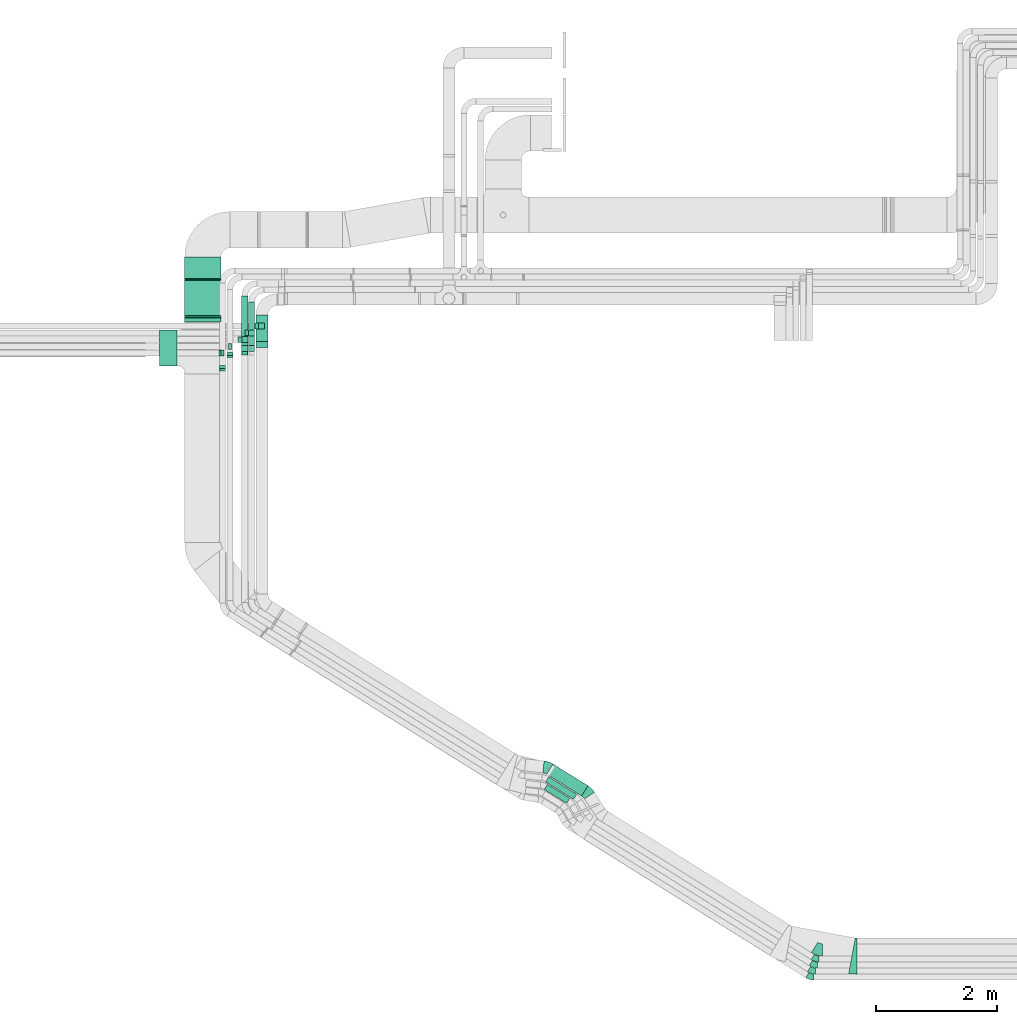
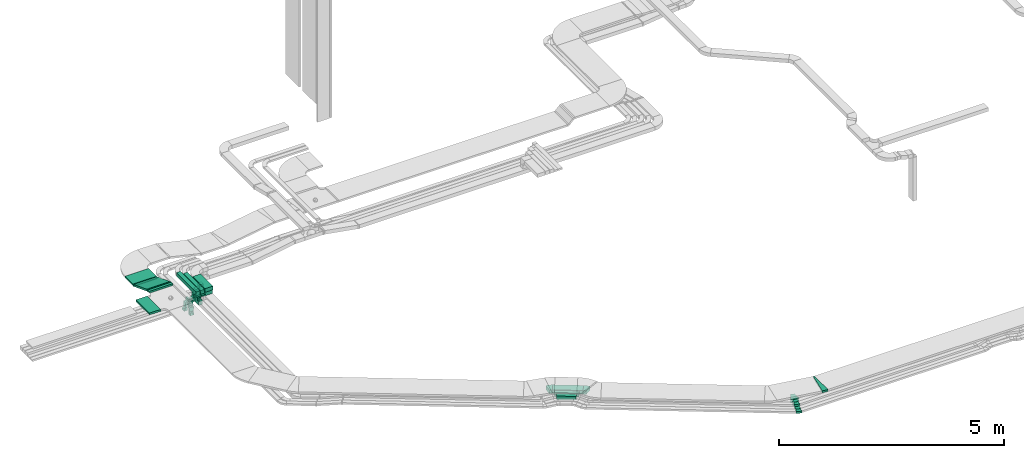
# One storey, part 7 of 28: 20 flow segments, 17 flow fittings.
"""IFC2X3 building model written with IfcOpenShell, lengths in millimetres."""

from ifc_helpers import new_model, entity, si_unit, converted_unit, derived_unit, direction, frame, frame_2d, origin, origin_2d_with_axis, place, context, subcontext, project, spatial, polyline, circle_curve, parameter, trimmed, segment, composite_curve, rectangle, outline, extrude, faceted_brep, source, transform, mapped, material, type_object, type_shapes, element, save


model = new_model("IFC2X3")

# Units and contexts
model_context = context("Model", 3, precision=0.01, world=origin(), true_north=direction((6.12303176911189e-17, 1.0)))
body_context = subcontext(model_context, "Body", "Model", "MODEL_VIEW")
ifc_project = project(units=[si_unit("LENGTHUNIT", "METRE", prefix="MILLI"), si_unit("AREAUNIT", "SQUARE_METRE"), si_unit("VOLUMEUNIT", "CUBIC_METRE"), converted_unit("PLANEANGLEUNIT", "DEGREE", entity("IfcRatioMeasure", 0.0174532925199433), si_unit("PLANEANGLEUNIT", "RADIAN"), dimensions=[0, 0, 0, 0, 0, 0, 0]), si_unit("MASSUNIT", "GRAM", prefix="KILO"), derived_unit("MASSDENSITYUNIT", [(si_unit("MASSUNIT", "GRAM", prefix="KILO"), 1), (si_unit("LENGTHUNIT", "METRE"), -3)]), derived_unit("MOMENTOFINERTIAUNIT", [(si_unit("LENGTHUNIT", "METRE"), 4)]), si_unit("TIMEUNIT", "SECOND"), si_unit("FREQUENCYUNIT", "HERTZ"), si_unit("THERMODYNAMICTEMPERATUREUNIT", "DEGREE_CELSIUS"), derived_unit("THERMALTRANSMITTANCEUNIT", [(si_unit("MASSUNIT", "GRAM", prefix="KILO"), 1), (si_unit("THERMODYNAMICTEMPERATUREUNIT", "KELVIN"), -1), (si_unit("TIMEUNIT", "SECOND"), -3)]), derived_unit("VOLUMETRICFLOWRATEUNIT", [(si_unit("LENGTHUNIT", "METRE"), 3), (si_unit("TIMEUNIT", "SECOND"), -1)]), derived_unit("MASSFLOWRATEUNIT", [(si_unit("MASSUNIT", "GRAM", prefix="KILO"), 1), (si_unit("TIMEUNIT", "SECOND"), -1)]), derived_unit("ROTATIONALFREQUENCYUNIT", [(si_unit("TIMEUNIT", "SECOND"), -1)]), si_unit("ELECTRICCURRENTUNIT", "AMPERE"), si_unit("ELECTRICVOLTAGEUNIT", "VOLT"), si_unit("POWERUNIT", "WATT"), si_unit("FORCEUNIT", "NEWTON", prefix="KILO"), si_unit("ILLUMINANCEUNIT", "LUX"), si_unit("LUMINOUSFLUXUNIT", "LUMEN"), si_unit("LUMINOUSINTENSITYUNIT", "CANDELA"), derived_unit("USERDEFINED", [(si_unit("MASSUNIT", "GRAM", prefix="KILO"), -1), (si_unit("LENGTHUNIT", "METRE"), -2), (si_unit("TIMEUNIT", "SECOND"), 3), (si_unit("LUMINOUSFLUXUNIT", "LUMEN"), 1)]), derived_unit("LINEARVELOCITYUNIT", [(si_unit("LENGTHUNIT", "METRE"), 1), (si_unit("TIMEUNIT", "SECOND"), -1)]), si_unit("PRESSUREUNIT", "PASCAL"), derived_unit("USERDEFINED", [(si_unit("LENGTHUNIT", "METRE"), -2), (si_unit("MASSUNIT", "GRAM", prefix="KILO"), 1), (si_unit("TIMEUNIT", "SECOND"), -2)]), derived_unit("LINEARFORCEUNIT", [(si_unit("MASSUNIT", "GRAM", prefix="KILO"), 1), (si_unit("LENGTHUNIT", "METRE"), 1), (si_unit("TIMEUNIT", "SECOND"), -2), (si_unit("LENGTHUNIT", "METRE"), -1)]), derived_unit("PLANARFORCEUNIT", [(si_unit("MASSUNIT", "GRAM", prefix="KILO"), 1), (si_unit("LENGTHUNIT", "METRE"), 1), (si_unit("TIMEUNIT", "SECOND"), -2), (si_unit("LENGTHUNIT", "METRE"), -2)])], contexts=[model_context])

# Site, building, storey
site_placement = place(None, origin())
site = spatial("IfcSite", under=ifc_project, at=site_placement, CompositionType="ELEMENT")
building_placement = place(site_placement, origin())
building = spatial("IfcBuilding", under=site, at=building_placement, CompositionType="ELEMENT")
storey_placement = place(building_placement, frame((0.0, 0.0, 4200.0)))
storey = spatial("IfcBuildingStorey", under=building, at=storey_placement, CompositionType="ELEMENT", Elevation=4200.0)

# Flow segments
cable_carrier_segment_type = type_object("IfcCableCarrierSegmentType", PredefinedType="CABLETRAYSEGMENT")
flow_segment_1_placement = place(storey_placement, frame((16162.99, 3174.28, 2836.0)))
element("IfcFlowSegment", 1, at=flow_segment_1_placement, inside=storey, type_object=cable_carrier_segment_type, context=body_context, shape_type="SweptSolid", body=[
    extrude(rectangle(XDim=440.17831343898, YDim=100.000000000001, at=origin_2d_with_axis()), frame((213.14, 159.03, 0.0), z_axis=(0.0, 0.0, 1.0), x_axis=(0.848048096156428, -0.529919264233201, 0.0)), (0.0, 0.0, 1.0), 99.9999999999989),
])
flow_segment_2_placement = place(storey_placement, frame((16188.32, 3242.66, 2836.0)))
element("IfcFlowSegment", 2, at=flow_segment_2_placement, inside=storey, type_object=cable_carrier_segment_type, context=body_context, shape_type="SweptSolid", body=[
    extrude(rectangle(XDim=544.386639758855, YDim=100.000000000001, at=origin_2d_with_axis()), frame((257.33, 186.64, 0.0), z_axis=(0.0, 0.0, 1.0), x_axis=(0.848048096156427, -0.529919264233204, 0.0)), (0.0, 0.0, 1.0), 99.9999999999989),
])
flow_segment_3_placement = place(storey_placement, frame((16206.86, 3298.15, 2836.0)))
element("IfcFlowSegment", 3, at=flow_segment_3_placement, inside=storey, type_object=cable_carrier_segment_type, context=body_context, shape_type="SweptSolid", body=[
    extrude(rectangle(XDim=680.786011222214, YDim=200.000000000001, at=origin_2d_with_axis()), frame((341.66, 265.19, 0.0), z_axis=(0.0, 0.0, 1.0), x_axis=(0.848048096156428, -0.529919264233203, 0.0)), (0.0, 0.0, 1.0), 99.9999999999989),
])
flow_segment_4_placement = place(storey_placement, frame((11383.59, 10733.65, 2975.0)))
element("IfcFlowSegment", 4, at=flow_segment_4_placement, inside=storey, type_object=cable_carrier_segment_type, context=body_context, shape_type="SweptSolid", body=[
    extrude(rectangle(XDim=544.131004135629, YDim=200.000000000002, at=origin_2d_with_axis()), frame((100.0, 272.07, 0.0), z_axis=(0.0, 0.0, 1.0), x_axis=(0.0, -1.0, 0.0)), (0.0, 0.0, 1.0), 100.0),
])
flow_segment_5_placement = place(storey_placement, frame((9785.26, 10426.35, 3110.0)))
element("IfcFlowSegment", 5, at=flow_segment_5_placement, inside=storey, type_object=cable_carrier_segment_type, context=body_context, shape_type="SweptSolid", body=[
    extrude(rectangle(XDim=288.329147634272, YDim=600.000000000002, at=origin_2d_with_axis()), frame((144.16, 300.0, 0.0), z_axis=(0.0, 0.0, 1.0), x_axis=(-1.0, 0.0, 0.0)), (0.0, 0.0, 1.0), 49.9999999999995),
])
flow_segment_6_placement = place(storey_placement, frame((10203.59, 11156.35, 3108.85)))
element("IfcFlowSegment", 6, at=flow_segment_6_placement, inside=storey, type_object=cable_carrier_segment_type, context=body_context, shape_type="SweptSolid", body=[
    extrude(rectangle(XDim=67.4394769447223, YDim=600.000000000002, at=origin_2d_with_axis()), frame((300.0, 33.72, 0.0), z_axis=(0.0, 0.0, 1.0), x_axis=(0.0, 1.0, 0.0)), (0.0, 0.0, 1.0), 49.9999999999995),
])
flow_segment_7_placement = place(storey_placement, frame((10203.59, 11244.21, 2875.16)))
element("IfcFlowSegment", 7, at=flow_segment_7_placement, inside=storey, type_object=cable_carrier_segment_type, context=body_context, shape_type="SweptSolid", body=[
    extrude(rectangle(XDim=49.9999999999996, YDim=641.534146168954, at=frame_2d((0.0, 0.0), x_axis=(0.0, 1.0))), frame((0.0, 308.42, 138.29), z_axis=(1.0, 0.0, 0.0), x_axis=(0.0, 0.933580426497194, -0.35836794954532)), (0.0, 0.0, 1.0), 600.000000000002),
])
flow_segment_8_placement = place(storey_placement, frame((10203.59, 11881.47, 2868.06)))
element("IfcFlowSegment", 8, at=flow_segment_8_placement, inside=storey, type_object=cable_carrier_segment_type, context=body_context, shape_type="SweptSolid", body=[
    extrude(rectangle(XDim=354.579149652475, YDim=600.000000000002, at=origin_2d_with_axis()), frame((300.0, 177.29, 0.0), z_axis=(0.0, 0.0, 1.0), x_axis=(0.0, -1.0, 0.0)), (0.0, 0.0, 1.0), 49.9999999999995),
])
flow_segment_9_placement = place(storey_placement, frame((11427.64, 11042.31, 2920.0)))
element("IfcFlowSegment", 9, at=flow_segment_9_placement, inside=storey, type_object=cable_carrier_segment_type, context=body_context, shape_type="SweptSolid", body=[
    extrude(rectangle(XDim=99.9999999999989, YDim=99.9999999999989, at=origin_2d_with_axis()), frame((50.0, 50.0, 0.0)), (0.0, 0.0, 1.0), 54.999999999903),
])
flow_segment_10_placement = place(storey_placement, frame((11383.59, 10735.23, 2880.0)))
element("IfcFlowSegment", 10, at=flow_segment_10_placement, inside=storey, type_object=cable_carrier_segment_type, context=body_context, shape_type="SweptSolid", body=[
    extrude(rectangle(XDim=200.000000000002, YDim=99.9999999999989, at=origin_2d_with_axis()), frame((100.0, 50.0, 0.0)), (0.0, 0.0, 1.0), 94.9999999996622),
])
flow_segment_11_placement = place(storey_placement, frame((11263.59, 10716.85, 2975.0)))
element("IfcFlowSegment", 11, at=flow_segment_11_placement, inside=storey, type_object=cable_carrier_segment_type, context=body_context, shape_type="SweptSolid", body=[
    extrude(rectangle(XDim=769.000000000009, YDim=99.9999999999989, at=origin_2d_with_axis()), frame((50.0, 384.5, 0.0), z_axis=(0.0, 0.0, 1.0), x_axis=(0.0, -1.0, 0.0)), (0.0, 0.0, 1.0), 100.000000000001),
])
flow_segment_12_placement = place(storey_placement, frame((11263.59, 10928.65, 2920.0)))
element("IfcFlowSegment", 12, at=flow_segment_12_placement, inside=storey, type_object=cable_carrier_segment_type, context=body_context, shape_type="SweptSolid", body=[
    extrude(rectangle(XDim=99.9999999999989, YDim=99.9999999999989, at=origin_2d_with_axis()), frame((50.0, 50.0, 0.0), z_axis=(0.0, 0.0, 1.0), x_axis=(0.0, -1.0, 0.0)), (0.0, 0.0, 1.0), 54.9999999997298),
])
flow_segment_13_placement = place(storey_placement, frame((11148.59, 10716.85, 2975.0)))
element("IfcFlowSegment", 13, at=flow_segment_13_placement, inside=storey, type_object=cable_carrier_segment_type, context=body_context, shape_type="SweptSolid", body=[
    extrude(rectangle(XDim=876.10399562814, YDim=99.9999999999989, at=origin_2d_with_axis()), frame((50.0, 438.05, 0.0), z_axis=(0.0, 0.0, 1.0), x_axis=(0.0, -1.0, 0.0)), (0.0, 0.0, 1.0), 99.9999999999978),
])
flow_segment_14_placement = place(storey_placement, frame((11148.59, 10667.04, 2940.0)))
element("IfcFlowSegment", 14, at=flow_segment_14_placement, inside=storey, type_object=cable_carrier_segment_type, context=body_context, shape_type="SweptSolid", body=[
    extrude(rectangle(XDim=99.9999999999989, YDim=99.9999999999989, at=origin_2d_with_axis()), frame((50.0, 50.0, 0.0), z_axis=(0.0, 0.0, 1.0), x_axis=(-1.0, 0.0, 0.0)), (0.0, 0.0, 1.0), 34.9999999999931),
])
flow_segment_15_placement = place(storey_placement, frame((11263.59, 10667.04, 2939.59)))
element("IfcFlowSegment", 15, at=flow_segment_15_placement, inside=storey, type_object=cable_carrier_segment_type, context=body_context, shape_type="SweptSolid", body=[
    extrude(rectangle(XDim=99.9999999999989, YDim=99.9999999999989, at=origin_2d_with_axis()), frame((50.0, 50.0, 0.0), z_axis=(0.0, 0.0, 1.0), x_axis=(-1.0, 0.0, 0.0)), (0.0, 0.0, 1.0), 35.408361324178),
])
flow_segment_16_placement = place(storey_placement, frame((10903.59, 10601.71, 2865.0)))
element("IfcFlowSegment", 16, at=flow_segment_16_placement, inside=storey, type_object=cable_carrier_segment_type, context=body_context, shape_type="SweptSolid", body=[
    extrude(rectangle(XDim=50.0000000000016, YDim=99.9999999999989, at=origin_2d_with_axis()), frame((50.0, 25.0, 0.0), z_axis=(0.0, 0.0, 1.0), x_axis=(0.0, -1.0, 0.0)), (0.0, 0.0, 1.0), 110.000000000012),
])
flow_segment_17_placement = place(storey_placement, frame((11150.72, 10815.79, 2920.0)))
element("IfcFlowSegment", 17, at=flow_segment_17_placement, inside=storey, type_object=cable_carrier_segment_type, context=body_context, shape_type="SweptSolid", body=[
    extrude(rectangle(XDim=99.9999999999989, YDim=99.9999999999989, at=origin_2d_with_axis()), frame((50.0, 50.0, 0.0), z_axis=(0.0, 0.0, 1.0), x_axis=(0.0, 1.0, 0.0)), (0.0, 0.0, 1.0), 54.9999999999951),
])
flow_segment_18_placement = place(storey_placement, frame((10928.59, 10700.79, 2810.0)))
element("IfcFlowSegment", 18, at=flow_segment_18_placement, inside=storey, type_object=cable_carrier_segment_type, context=body_context, shape_type="SweptSolid", body=[
    extrude(rectangle(XDim=99.9999999999989, YDim=50.0000000000016, at=origin_2d_with_axis()), frame((25.0, 50.0, 0.0), z_axis=(0.0, 0.0, 1.0), x_axis=(0.0, -1.0, 0.0)), (0.0, 0.0, 1.0), 165.000000000001),
])
flow_segment_19_placement = place(storey_placement, frame((10783.59, 10384.17, 2865.0)))
element("IfcFlowSegment", 19, at=flow_segment_19_placement, inside=storey, type_object=cable_carrier_segment_type, context=body_context, shape_type="SweptSolid", body=[
    extrude(rectangle(XDim=99.9999999999989, YDim=50.0000000000016, at=origin_2d_with_axis()), frame((50.0, 25.0, 0.0), z_axis=(0.0, 0.0, 1.0), x_axis=(-1.0, 0.0, 0.0)), (0.0, 0.0, 1.0), 110.000000000005),
])
flow_segment_20_placement = place(storey_placement, frame((10808.59, 10590.79, 2845.0)))
element("IfcFlowSegment", 20, at=flow_segment_20_placement, inside=storey, type_object=cable_carrier_segment_type, context=body_context, shape_type="SweptSolid", body=[
    extrude(rectangle(XDim=99.9999999999989, YDim=50.0000000000016, at=origin_2d_with_axis()), frame((25.0, 50.0, 0.0), z_axis=(0.0, 0.0, 1.0), x_axis=(0.0, 1.0, 0.0)), (0.0, 0.0, 1.0), 130.000000000003),
])

# Flow fittings
ifc_material = material()
cable_carrier_fitting_type_1 = type_object("IfcCableCarrierFittingType", PredefinedType="NOTDEFINED", material=ifc_material)
shared_shape_1 = source(origin(), body_context, "Body", "Brep", [
    faceted_brep([(-15.19, -25.0, 300.0), (-15.19, 25.0, 300.0), (-15.19, 25.0, 297.46), (-15.19, -22.46, 297.46), (-15.19, -22.46, -297.46), (-15.19, 25.0, -297.46), (-15.19, 25.0, -300.0), (-15.19, -25.0, -300.0), (23.14, -17.89, 300.0), (23.14, -17.89, -300.0), (5.23, 28.78, -300.0), (5.23, 28.78, -297.46), (22.23, -15.52, -297.46), (22.23, -15.52, 297.46), (5.23, 28.78, 297.46), (5.23, 28.78, 300.0), (4.63, -25.0, 300.0), (-4.63, 25.0, 300.0), (-4.63, 25.0, 297.46), (4.16, -22.46, 297.46), (4.16, -22.46, -297.46), (-4.63, 25.0, -297.46), (-4.63, 25.0, -300.0), (4.63, -25.0, -300.0)], [[[0, 1, 2, 3, 4, 5, 6, 7]], [[8, 9, 10, 11, 12, 13, 14, 15]], [[1, 0, 16, 8, 15, 17]], [[2, 1, 17, 18]], [[3, 2, 18, 14, 13, 19]], [[4, 3, 19, 20]], [[5, 4, 20, 12, 11, 21]], [[6, 5, 21, 22]], [[7, 6, 22, 10, 9, 23]], [[0, 7, 23, 16]], [[18, 17, 15, 14]], [[20, 19, 13, 12]], [[22, 21, 11, 10]], [[16, 23, 9, 8]]]),
])
type_shapes(cable_carrier_fitting_type_1, [shared_shape_1])
for number, where, z_axis, x_axis in (
    (21, (10503.59, 11238.98, 3133.85), (-1.0, 0.0, 0.0), (0.0, 1.0, 0.0)),
    (22, (10503.59, 11866.28, 2893.06), (-1.0, 0.0, 0.0), (0.0, -1.0, 0.0)),
):
    element("IfcFlowFitting", number, at=place(storey_placement, frame(where, z_axis=z_axis, x_axis=x_axis)), inside=storey, type_object=cable_carrier_fitting_type_1, material=ifc_material, context=body_context, shape_type="MappedRepresentation", body=[
        mapped(shared_shape_1, transform((0.0, 0.0, 0.0), scale=1.0)),
    ])
cable_carrier_fitting_type_2 = type_object("IfcCableCarrierFittingType", PredefinedType="NOTDEFINED", material=ifc_material)
shared_shape_2 = source(origin(), body_context, "Body", "Brep", [
    faceted_brep([(-110.0, -50.0, 50.0), (-110.0, 50.0, 50.0), (-110.0, 50.0, 47.46), (-110.0, -47.46, 47.46), (-110.0, -47.46, -47.46), (-110.0, 50.0, -47.46), (-110.0, 50.0, -50.0), (-110.0, -50.0, -50.0), (50.0, 110.0, 50.0), (50.0, 110.0, -50.0), (-50.0, 110.0, -50.0), (-50.0, 110.0, -47.46), (47.46, 110.0, -47.46), (47.46, 110.0, 47.46), (-50.0, 110.0, 47.46), (-50.0, 110.0, 50.0), (50.0, -50.0, 50.0), (-50.0, 50.0, 50.0), (-50.0, 50.0, 47.46), (47.46, -47.46, 47.46), (47.46, -47.46, -47.46), (-50.0, 50.0, -47.46), (-50.0, 50.0, -50.0), (50.0, -50.0, -50.0)], [[[0, 1, 2, 3, 4, 5, 6, 7]], [[8, 9, 10, 11, 12, 13, 14, 15]], [[1, 0, 16, 8, 15, 17]], [[2, 1, 17, 18]], [[3, 2, 18, 14, 13, 19]], [[4, 3, 19, 20]], [[5, 4, 20, 12, 11, 21]], [[6, 5, 21, 22]], [[7, 6, 22, 10, 9, 23]], [[0, 7, 23, 16]], [[18, 17, 15, 14]], [[20, 19, 13, 12]], [[22, 21, 11, 10]], [[16, 23, 9, 8]]]),
])
type_shapes(cable_carrier_fitting_type_2, [shared_shape_2])
for number, where, z_axis, x_axis in (
    (23, (11477.64, 11092.31, 2810.0), (0.0, -1.0, 0.0), (1.0, 0.0, 0.0)),
    (24, (11313.59, 10978.65, 2810.0), (0.0, -1.0, 0.0), (1.0, 0.0, 0.0)),
    (25, (11198.59, 10717.04, 2830.0), (1.0, 0.0, 0.0), (0.0, 1.0, 0.0)),
    (26, (11200.72, 10865.79, 2810.0), (0.0, 1.0, 0.0), (0.0, 0.0, -1.0)),
):
    element("IfcFlowFitting", number, at=place(storey_placement, frame(where, z_axis=z_axis, x_axis=x_axis)), inside=storey, type_object=cable_carrier_fitting_type_2, material=ifc_material, context=body_context, shape_type="MappedRepresentation", body=[
        mapped(shared_shape_2, transform((0.0, 0.0, 0.0), scale=1.0)),
    ])
cable_carrier_fitting_type_3 = type_object("IfcCableCarrierFittingType", PredefinedType="NOTDEFINED", material=ifc_material)
shared_shape_3 = source(origin(), body_context, "Body", "Brep", [
    faceted_brep([(-60.0, -25.0, 50.0), (-60.0, 25.0, 50.0), (-60.0, 25.0, 47.46), (-60.0, -22.46, 47.46), (-60.0, -22.46, -47.46), (-60.0, 25.0, -47.46), (-60.0, 25.0, -50.0), (-60.0, -25.0, -50.0), (25.0, 60.0, 50.0), (25.0, 60.0, -50.0), (-25.0, 60.0, -50.0), (-25.0, 60.0, -47.46), (22.46, 60.0, -47.46), (22.46, 60.0, 47.46), (-25.0, 60.0, 47.46), (-25.0, 60.0, 50.0), (25.0, -25.0, 50.0), (-25.0, 25.0, 50.0), (-25.0, 25.0, 47.46), (22.46, -22.46, 47.46), (22.46, -22.46, -47.46), (-25.0, 25.0, -47.46), (-25.0, 25.0, -50.0), (25.0, -25.0, -50.0)], [[[0, 1, 2, 3, 4, 5, 6, 7]], [[8, 9, 10, 11, 12, 13, 14, 15]], [[1, 0, 16, 8, 15, 17]], [[2, 1, 17, 18]], [[3, 2, 18, 14, 13, 19]], [[4, 3, 19, 20]], [[5, 4, 20, 12, 11, 21]], [[6, 5, 21, 22]], [[7, 6, 22, 10, 9, 23]], [[0, 7, 23, 16]], [[18, 17, 15, 14]], [[20, 19, 13, 12]], [[22, 21, 11, 10]], [[16, 23, 9, 8]]]),
])
type_shapes(cable_carrier_fitting_type_3, [shared_shape_3])
for number, where, z_axis, x_axis in (
    (27, (10833.59, 10640.79, 2785.0), (0.0, -1.0, 0.0), (1.0, 0.0, 0.0)),
    (28, (10953.59, 10626.71, 2805.0), (-1.0, 0.0, 0.0), (0.0, 0.0, -1.0)),
    (29, (10833.59, 10409.17, 2805.0), (-1.0, 0.0, 0.0), (0.0, 0.0, -1.0)),
):
    element("IfcFlowFitting", number, at=place(storey_placement, frame(where, z_axis=z_axis, x_axis=x_axis)), inside=storey, type_object=cable_carrier_fitting_type_3, material=ifc_material, context=body_context, shape_type="MappedRepresentation", body=[
        mapped(shared_shape_3, transform((0.0, 0.0, 0.0), scale=1.0)),
    ])
cable_carrier_fitting_type_4 = type_object("IfcCableCarrierFittingType", Name="470_DKC_S5_Variable Angle Elbow 0-45:-", PredefinedType="NOTDEFINED", material=ifc_material)
shared_shape_4 = source(origin(), body_context, "Body", "SweptSolid", [
    extrude(outline(composite_curve([segment(polyline([(-53.95, -65.33), (-52.95, -65.33)]), True, "CONTINUOUS"), segment(trimmed(circle_curve(frame_2d((-52.95, 184.67), x_axis=(0.0, -1.0)), 250.0), [parameter(0.0)], [parameter(32.0000000000001)], True, "PARAMETER"), True, "CONTINUOUS"), segment(polyline([(79.53, -27.34), (80.37, -26.81)]), True, "CONTINUOUS"), segment(polyline([(80.37, -26.81), (27.38, 58.0)]), True, "CONTINUOUS"), segment(polyline([(27.38, 58.0), (26.53, 57.47)]), True, "CONTINUOUS"), segment(trimmed(circle_curve(frame_2d((-52.95, 184.67), x_axis=(0.0, -1.0)), 150.0), [parameter(0.0)], [parameter(32.0000000000001)], True, "PARAMETER"), False, "CONTINUOUS"), segment(polyline([(-52.95, 34.67), (-53.95, 34.67)]), True, "CONTINUOUS"), segment(polyline([(-53.95, 34.67), (-53.95, -65.33)]), True, "CONTINUOUS")], self_intersect=False)), frame((-4.4, 15.33, -50.0)), (0.0, 0.0, 1.0), 100.0),
])
type_shapes(cable_carrier_fitting_type_4, [shared_shape_4])
for number, where, z_axis, x_axis, name in (
    (30, (20665.47, 596.66, 2886.0), (0.0, 0.0, 1.0), (0.848048096156421, -0.529919264233213, 0.0), "470_DKC_S5_Variable Angle Elbow 0-45:-"),
    (31, (20635.36, 496.66, 2886.0), (0.0, 0.0, 1.0), (0.848048096156424, -0.529919264233208, 0.0), "470_DKC_S5_Variable Angle Elbow 0-45:-"),
):
    element("IfcFlowFitting", number, at=place(storey_placement, frame(where, z_axis=z_axis, x_axis=x_axis)), inside=storey, type_object=cable_carrier_fitting_type_4, material=ifc_material, Name=name, ObjectType="470_DKC_S5_Variable Angle Elbow 0-45:-", context=body_context, shape_type="MappedRepresentation", body=[
        mapped(shared_shape_4, transform((0.0, 0.0, 0.0), scale=1.0)),
    ])
cable_carrier_fitting_type_5 = type_object("IfcCableCarrierFittingType", Name="470_DKC_S5_Variable Angle Elbow 0-45:-", PredefinedType="NOTDEFINED", material=ifc_material)
shared_shape_5 = source(origin(), body_context, "Body", "SweptSolid", [
    extrude(outline(composite_curve([segment(polyline([(-53.95, -65.33), (-52.95, -65.33)]), True, "CONTINUOUS"), segment(trimmed(circle_curve(frame_2d((-52.95, 184.67), x_axis=(0.0, -1.0)), 250.0), [parameter(0.0)], [parameter(32.0000000000003)], True, "PARAMETER"), True, "CONTINUOUS"), segment(polyline([(79.53, -27.34), (80.37, -26.81)]), True, "CONTINUOUS"), segment(polyline([(80.37, -26.81), (27.38, 58.0)]), True, "CONTINUOUS"), segment(polyline([(27.38, 58.0), (26.53, 57.47)]), True, "CONTINUOUS"), segment(trimmed(circle_curve(frame_2d((-52.95, 184.67), x_axis=(0.0, -1.0)), 150.0), [parameter(0.0)], [parameter(32.0000000000003)], True, "PARAMETER"), False, "CONTINUOUS"), segment(polyline([(-52.95, 34.67), (-53.95, 34.67)]), True, "CONTINUOUS"), segment(polyline([(-53.95, 34.67), (-53.95, -65.33)]), True, "CONTINUOUS")], self_intersect=False)), frame((-4.4, 15.33, -25.0)), (0.0, 0.0, 1.0), 50.0),
])
type_shapes(cable_carrier_fitting_type_5, [shared_shape_5])
for number, where, z_axis, x_axis, name in (
    (32, (20604.76, 396.66, 2861.0), (0.0, 0.0, 1.0), (0.848048096156424, -0.529919264233208, 0.0), "470_DKC_S5_Variable Angle Elbow 0-45:-"),
    (33, (20575.82, 296.66, 2861.0), (0.0, 0.0, 1.0), (0.848048096156425, -0.529919264233207, 0.0), "470_DKC_S5_Variable Angle Elbow 0-45:-"),
):
    element("IfcFlowFitting", number, at=place(storey_placement, frame(where, z_axis=z_axis, x_axis=x_axis)), inside=storey, type_object=cable_carrier_fitting_type_5, material=ifc_material, Name=name, ObjectType="470_DKC_S5_Variable Angle Elbow 0-45:-", context=body_context, shape_type="MappedRepresentation", body=[
        mapped(shared_shape_5, transform((0.0, 0.0, 0.0), scale=1.0)),
    ])
cable_carrier_fitting_type_6 = type_object("IfcCableCarrierFittingType", Name="470_DKC_S5_Variable Angle Elbow 0-45:-", PredefinedType="NOTDEFINED", material=ifc_material)
shared_shape_6 = source(origin(), body_context, "Body", "SweptSolid", [
    extrude(outline(composite_curve([segment(polyline([(-67.2, -119.13), (-66.2, -119.13)]), True, "CONTINUOUS"), segment(trimmed(circle_curve(frame_2d((-66.2, 230.87), x_axis=(0.0, -1.0)), 350.0), [parameter(0.0)], [parameter(32.0000000000002)], True, "PARAMETER"), True, "CONTINUOUS"), segment(polyline([(119.27, -65.94), (120.12, -65.41)]), True, "CONTINUOUS"), segment(polyline([(120.12, -65.41), (14.13, 104.2)]), True, "CONTINUOUS"), segment(polyline([(14.13, 104.2), (13.29, 103.67)]), True, "CONTINUOUS"), segment(trimmed(circle_curve(frame_2d((-66.2, 230.87), x_axis=(0.0, -1.0)), 150.0), [parameter(0.0)], [parameter(32.0000000000002)], True, "PARAMETER"), False, "CONTINUOUS"), segment(polyline([(-66.2, 80.87), (-67.2, 80.87)]), True, "CONTINUOUS"), segment(polyline([(-67.2, 80.87), (-67.2, -119.13)]), True, "CONTINUOUS")], self_intersect=False)), frame((-5.48, 19.13, -50.0)), (0.0, 0.0, 1.0), 100.0),
])
type_shapes(cable_carrier_fitting_type_6, [shared_shape_6])
flow_fitting_1_placement = place(storey_placement, frame((20709.33, 746.66, 2886.0), z_axis=(0.0, 0.0, 1.0), x_axis=(0.848048096156424, -0.529919264233208, 0.0)))
element("IfcFlowFitting", 34, at=flow_fitting_1_placement, inside=storey, type_object=cable_carrier_fitting_type_6, material=ifc_material, Name="470_DKC_S5_Variable Angle Elbow 0-45:-", ObjectType="470_DKC_S5_Variable Angle Elbow 0-45:-", context=body_context, shape_type="MappedRepresentation", body=[
    mapped(shared_shape_6, transform((0.0, 0.0, 0.0), scale=1.0)),
])
cable_carrier_fitting_type_7 = type_object("IfcCableCarrierFittingType", Name="470_DKC_S5_Variable Angle Elbow 0-45:-", PredefinedType="NOTDEFINED", material=ifc_material)
shared_shape_7 = source(origin(), body_context, "Body", "SweptSolid", [
    extrude(outline(composite_curve([segment(polyline([(-42.12, -303.84), (-41.12, -303.84)]), True, "CONTINUOUS"), segment(trimmed(circle_curve(frame_2d((-41.12, 446.16), x_axis=(0.0, -1.0)), 750.0), [parameter(0.0)], [parameter(10.5320187983697)], True, "PARAMETER"), True, "CONTINUOUS"), segment(polyline([(95.97, -291.2), (96.95, -291.02)]), True, "CONTINUOUS"), segment(polyline([(96.95, -291.02), (-12.72, 298.87)]), True, "CONTINUOUS"), segment(polyline([(-12.72, 298.87), (-13.7, 298.69)]), True, "CONTINUOUS"), segment(trimmed(circle_curve(frame_2d((-41.12, 446.16), x_axis=(0.0, -1.0)), 150.0), [parameter(0.0)], [parameter(10.5320187983697)], True, "PARAMETER"), False, "CONTINUOUS"), segment(polyline([(-41.12, 296.16), (-42.12, 296.16)]), True, "CONTINUOUS"), segment(polyline([(-42.12, 296.16), (-42.12, -303.84)]), True, "CONTINUOUS")], self_intersect=False)), frame((-0.35, 3.84, -25.0)), (0.0, 0.0, 1.0), 50.0000000000017),
])
type_shapes(cable_carrier_fitting_type_7, [shared_shape_7])
flow_fitting_2_placement = place(storey_placement, frame((21310.05, 641.66, 3133.85), z_axis=(0.0, 0.0, 1.0), x_axis=(0.983152914728378, -0.182784972744192, 0.0)))
element("IfcFlowFitting", 35, at=flow_fitting_2_placement, inside=storey, type_object=cable_carrier_fitting_type_7, material=ifc_material, Name="470_DKC_S5_Variable Angle Elbow 0-45:-", ObjectType="470_DKC_S5_Variable Angle Elbow 0-45:-", context=body_context, shape_type="MappedRepresentation", body=[
    mapped(shared_shape_7, transform((0.0, 0.0, 0.0), scale=1.0)),
])
cable_carrier_fitting_type_8 = type_object("IfcCableCarrierFittingType", Name="470_DKC_S5_Variable Angle Elbow 0-45:-", PredefinedType="NOTDEFINED", material=ifc_material)
shared_shape_8 = source(origin(), body_context, "Body", "SweptSolid", [
    extrude(outline(composite_curve([segment(polyline([(-55.6, -112.67), (-54.6, -112.67)]), True, "CONTINUOUS"), segment(trimmed(circle_curve(frame_2d((-54.6, 237.33), x_axis=(0.0, -1.0)), 350.0), [parameter(0.0)], [parameter(25.9108682245477)], True, "PARAMETER"), True, "CONTINUOUS"), segment(polyline([(98.34, -77.49), (99.24, -77.05)]), True, "CONTINUOUS"), segment(polyline([(99.24, -77.05), (11.85, 102.84)]), True, "CONTINUOUS"), segment(polyline([(11.85, 102.84), (10.95, 102.4)]), True, "CONTINUOUS"), segment(trimmed(circle_curve(frame_2d((-54.6, 237.33), x_axis=(0.0, -1.0)), 150.0), [parameter(0.0)], [parameter(25.9108682245477)], True, "PARAMETER"), False, "CONTINUOUS"), segment(polyline([(-54.6, 87.33), (-55.6, 87.33)]), True, "CONTINUOUS"), segment(polyline([(-55.6, 87.33), (-55.6, -112.67)]), True, "CONTINUOUS")], self_intersect=False)), frame((-2.92, 12.67, -50.0)), (0.0, 0.0, 1.0), 100.0),
])
type_shapes(cable_carrier_fitting_type_8, [shared_shape_8])
flow_fitting_3_placement = place(storey_placement, frame((16210.23, 3774.73, 2886.0), z_axis=(0.0, 0.0, 1.0), x_axis=(-0.848048096156425, 0.529919264233207, 0.0)))
element("IfcFlowFitting", 36, at=flow_fitting_3_placement, inside=storey, type_object=cable_carrier_fitting_type_8, material=ifc_material, Name="470_DKC_S5_Variable Angle Elbow 0-45:-", ObjectType="470_DKC_S5_Variable Angle Elbow 0-45:-", context=body_context, shape_type="MappedRepresentation", body=[
    mapped(shared_shape_8, transform((0.0, 0.0, 0.0), scale=1.0)),
])
cable_carrier_fitting_type_9 = type_object("IfcCableCarrierFittingType", Name="470_DKC_S5_Variable Angle Elbow 0-45:-", PredefinedType="NOTDEFINED", material=ifc_material)
shared_shape_9 = source(origin(), body_context, "Body", "SweptSolid", [
    extrude(outline(composite_curve([segment(polyline([(-53.75, -111.79), (-52.75, -111.79)]), True, "CONTINUOUS"), segment(trimmed(circle_curve(frame_2d((-52.75, 238.21), x_axis=(0.0, -1.0)), 350.0), [parameter(0.0)], [parameter(24.9746468146404)], True, "PARAMETER"), True, "CONTINUOUS"), segment(polyline([(95.02, -79.07), (95.93, -78.64)]), True, "CONTINUOUS"), segment(polyline([(95.93, -78.64), (11.49, 102.65)]), True, "CONTINUOUS"), segment(polyline([(11.49, 102.65), (10.58, 102.23)]), True, "CONTINUOUS"), segment(trimmed(circle_curve(frame_2d((-52.75, 238.21), x_axis=(0.0, -1.0)), 150.0), [parameter(0.0)], [parameter(24.9746468146404)], True, "PARAMETER"), False, "CONTINUOUS"), segment(polyline([(-52.75, 88.21), (-53.75, 88.21)]), True, "CONTINUOUS"), segment(polyline([(-53.75, 88.21), (-53.75, -111.79)]), True, "CONTINUOUS")], self_intersect=False)), frame((-2.61, 11.79, -50.0)), (0.0, 0.0, 1.0), 100.0),
])
type_shapes(cable_carrier_fitting_type_9, [shared_shape_9])
flow_fitting_4_placement = place(storey_placement, frame((16884.99, 3353.09, 2886.0), z_axis=(0.0, 0.0, 1.0), x_axis=(-0.545010090523452, 0.838429484946479, 0.0)))
element("IfcFlowFitting", 37, at=flow_fitting_4_placement, inside=storey, type_object=cable_carrier_fitting_type_9, material=ifc_material, Name="470_DKC_S5_Variable Angle Elbow 0-45:-", ObjectType="470_DKC_S5_Variable Angle Elbow 0-45:-", context=body_context, shape_type="MappedRepresentation", body=[
    mapped(shared_shape_9, transform((0.0, 0.0, 0.0), scale=1.0)),
])

save(model, "model.ifc")
